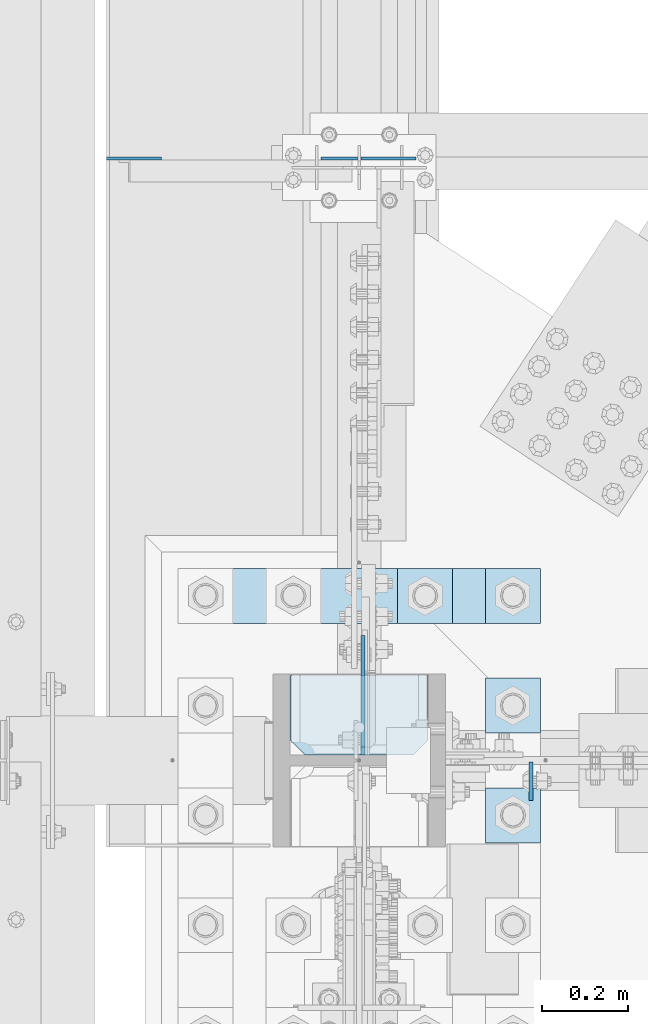
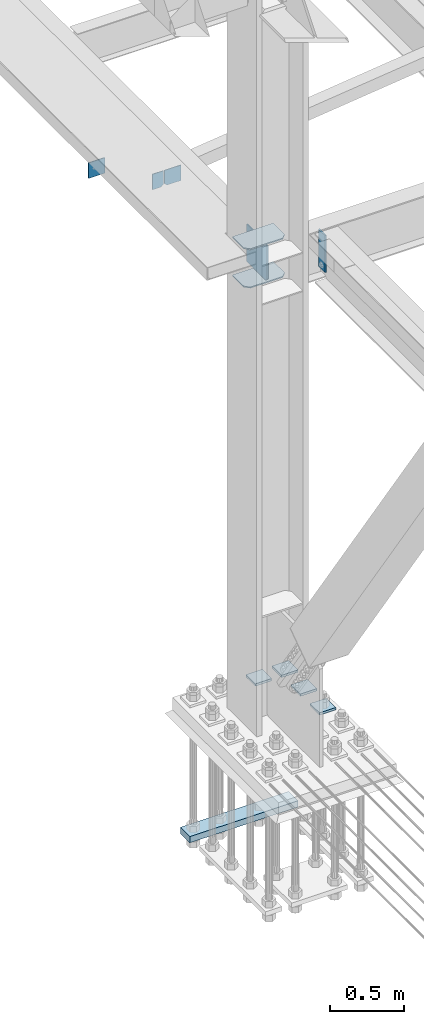
# One storey, part 3275 of 3843: 12 plates, 4 elements without a shape of their own.
"""IFC2X3 building model written with IfcOpenShell, lengths in millimetres."""

import ifcopenshell
import ifcopenshell.guid

model = None  # the IFC model being written
_history = None  # IfcOwnerHistory: only IFC2X3 demands one
_inside = {}  # id of a spatial element -> (the spatial element, [elements in it])
_under = {}  # id of a project, library or spatial element -> (it, [spatial elements below it])
_declared = {}  # id of a project -> (the project, [libraries it declares])
_typed = {}  # id of a type object -> (the type object, [elements of that type])
_made_of = {}  # id of a material, layer set ... -> (it, [elements and type objects made of it])


def new_model(schema):
    """Start an empty IFC model of exactly this schema.

    Asked for "IFC4X3", IfcOpenShell would pick the latest addendum, in which some entities
    have other attributes; the version numbers below select the first issue.
    IFC2X3 requires an IfcOwnerHistory on every rooted entity: one is made here for all.
    """
    global model, _history
    if schema == "IFC4X3":
        model = ifcopenshell.file(schema_version=(4, 3, 0, 0))
    else:
        model = ifcopenshell.file(schema=schema)
    _inside.clear()
    _under.clear()
    _declared.clear()
    _typed.clear()
    _made_of.clear()
    _history = None
    if model.schema == "IFC2X3":
        org = make("IfcOrganization", Name="unknown")
        user = make(
            "IfcPersonAndOrganization",
            ThePerson=make("IfcPerson", FamilyName="unknown"),
            TheOrganization=org,
        )
        app = make(
            "IfcApplication",
            ApplicationDeveloper=org,
            Version="unknown",
            ApplicationFullName="unknown",
            ApplicationIdentifier="unknown",
        )
        _history = make(
            "IfcOwnerHistory",
            OwningUser=user,
            OwningApplication=app,
            ChangeAction="ADDED",
            CreationDate=0,
        )
    return model


def make(cls, **values):
    """One entity of the class cls with the attributes given. An attribute that is None is left unset."""
    return model.create_entity(
        cls, **{name: value for name, value in values.items() if value is not None}
    )


def rooted(cls, **values):
    """An entity with a GlobalId (a new one), such as an element, a storey or a relation."""
    return make(cls, GlobalId=ifcopenshell.guid.new(), OwnerHistory=_history, **values)


def si_unit(unit_type, name, prefix=None):
    """IfcSIUnit, for example si_unit("LENGTHUNIT", "METRE", prefix="MILLI")."""
    return make("IfcSIUnit", UnitType=unit_type, Prefix=prefix, Name=name)


def assignment(units):
    """IfcUnitAssignment: the units of a project."""
    return None if units is None else make("IfcUnitAssignment", Units=units)


def point(xyz):
    """IfcCartesianPoint."""
    return None if xyz is None else make("IfcCartesianPoint", Coordinates=xyz)


def direction(xyz):
    """IfcDirection."""
    return None if xyz is None else make("IfcDirection", DirectionRatios=xyz)


def frame(location, z_axis=None, x_axis=None):
    """IfcAxis2Placement3D, a coordinate frame: its origin and axes. An axis left out is left unset."""
    return make(
        "IfcAxis2Placement3D",
        Location=point(location),
        Axis=direction(z_axis),
        RefDirection=direction(x_axis),
    )


def origin_with_axes():
    """The frame at (0, 0, 0) with the z axis (0, 0, 1) and the x axis (1, 0, 0) written out."""
    return frame((0.0, 0.0, 0.0), z_axis=(0.0, 0.0, 1.0), x_axis=(1.0, 0.0, 0.0))


def place(relative_to, where):
    """IfcLocalPlacement: puts the frame where relative to a parent placement (None: the world)."""
    return make(
        "IfcLocalPlacement", PlacementRelTo=relative_to, RelativePlacement=where
    )


def context(
    kind, dimensions, precision=None, world=None, true_north=None, identifier=None
):
    """IfcGeometricRepresentationContext, for example the 3D "Model" context."""
    return make(
        "IfcGeometricRepresentationContext",
        ContextIdentifier=identifier,
        ContextType=kind,
        CoordinateSpaceDimension=dimensions,
        Precision=precision,
        WorldCoordinateSystem=world,
        TrueNorth=true_north,
    )


def subcontext(parent, identifier, kind, view, scale=None):
    """IfcGeometricRepresentationSubContext, for example "Body" below "Model"."""
    return make(
        "IfcGeometricRepresentationSubContext",
        ContextIdentifier=identifier,
        ContextType=kind,
        ParentContext=parent,
        TargetScale=scale,
        TargetView=view,
    )


def project(units=None, contexts=None):
    """IfcProject with its units and contexts."""
    return rooted(
        "IfcProject",
        Name="project",
        RepresentationContexts=contexts,
        UnitsInContext=assignment(units),
    )


def spatial(cls, under=None, at=None, **own):
    """A site, building, storey or space (cls), placed at a placement, below another one or the project."""
    s = rooted(cls, ObjectPlacement=at, **own)
    if under is not None:
        _under.setdefault(under.id(), (under, []))[1].append(s)
    return s


def faces_of(points, faces, orient=None, outer=None):
    """IfcFace entities. A face is a list of loops; a loop is a list of indices into points, from 0.

    orient and outer hold one flag for each loop. By default every Orientation is true, the
    first loop of a face is its IfcFaceOuterBound and the others are IfcFaceBound.
    """
    made = []
    for i, loops in enumerate(faces):
        bounds = []
        for j, loop in enumerate(loops):
            is_outer = j == 0 if outer is None else outer[i][j]
            bounds.append(
                make(
                    "IfcFaceOuterBound" if is_outer else "IfcFaceBound",
                    Bound=make("IfcPolyLoop", Polygon=[points[k] for k in loop]),
                    Orientation=True if orient is None else orient[i][j],
                )
            )
        made.append(make("IfcFace", Bounds=bounds))
    return made


def faceted_brep(points, faces, orient=None, outer=None, voids=None):
    """IfcFacetedBrep: a solid bounded by flat faces; with voids (closed shells), ...WithVoids."""
    shared = [point(p) for p in points]
    hull = make("IfcClosedShell", CfsFaces=faces_of(shared, faces, orient, outer))
    if voids is None:
        return make("IfcFacetedBrep", Outer=hull)
    return make(
        "IfcFacetedBrepWithVoids",
        Outer=hull,
        Voids=[
            make(cls, CfsFaces=faces_of(shared, fs, o, b)) for cls, fs, o, b in voids
        ],
    )


def shape(context_of_items, identifier, shape_type, items):
    """IfcShapeRepresentation: the items that make up one representation, for example the "Body"."""
    return make(
        "IfcShapeRepresentation",
        ContextOfItems=context_of_items,
        RepresentationIdentifier=identifier,
        RepresentationType=shape_type,
        Items=items,
    )


def material(Name=None, Category=None):
    """IfcMaterial."""
    return make("IfcMaterial", Name=Name, Category=Category)


def made_of(thing, what):
    """Note that an element or type object is made of a material, layer set ...; save() writes the relation."""
    if what is not None:
        _made_of.setdefault(what.id(), (what, []))[1].append(thing)
    return thing


def type_object(cls, material=None, **own):
    """A type object (cls), such as IfcWallType, which elements share."""
    return made_of(rooted(cls, **own), material)


def element(
    cls,
    number,
    at=None,
    inside=None,
    cuts=None,
    type_object=None,
    material=None,
    context=None,
    identifier="Body",
    shape_type=None,
    held_by="IfcProductDefinitionShape",
    body=None,
    shapes=None,
    **own,
):
    """One element of the class cls, such as IfcWall. Its Tag is "e" and its number.

    at: its placement. inside: the storey or other place that contains it. cuts: it is an
    opening in that element (IfcRelVoidsElement). A single representation is given by context,
    identifier, shape_type and body (its items); several are given by shapes. held_by: the class
    of the entity that holds the representations. save() writes the other relations.
    """
    e = rooted(cls, Tag="e%d" % number, ObjectPlacement=at, **own)
    if body is not None:
        shapes = [shape(context, identifier, shape_type, body)]
    if shapes is not None:
        e.Representation = make(held_by, Representations=shapes)
    if inside is not None:
        _inside.setdefault(inside.id(), (inside, []))[1].append(e)
    if cuts is not None:
        rooted(
            "IfcRelVoidsElement", RelatingBuildingElement=cuts, RelatedOpeningElement=e
        )
    if type_object is not None:
        _typed.setdefault(type_object.id(), (type_object, []))[1].append(e)
    return made_of(e, material)


def aggregate(whole, parts):
    """IfcRelAggregates: a whole, such as a stair, and the parts it consists of."""
    return rooted("IfcRelAggregates", RelatingObject=whole, RelatedObjects=parts)


def save(model, path):
    """Write the relations noted so far, then the file.

    IfcRelAggregates (storeys below a building ...), IfcRelContainedInSpatialStructure (elements
    in a storey), IfcRelDefinesByType, IfcRelAssociatesMaterial and IfcRelDeclares: one each for
    every whole, place, type object, material and project.
    """
    for whole, parts in _under.values():
        aggregate(whole, parts)
    for where, things in _inside.values():
        rooted(
            "IfcRelContainedInSpatialStructure",
            RelatedElements=things,
            RelatingStructure=where,
        )
    for kind, things in _typed.values():
        rooted("IfcRelDefinesByType", RelatedObjects=things, RelatingType=kind)
    for what, things in _made_of.values():
        rooted("IfcRelAssociatesMaterial", RelatedObjects=things, RelatingMaterial=what)
    for by, libraries in _declared.values():
        rooted("IfcRelDeclares", RelatingContext=by, RelatedDefinitions=libraries)
    model.write(path)


model = new_model("IFC2X3")

# Units and contexts
model_context = context("Model", 3, precision=1e-05, world=origin_with_axes())
body_context = subcontext(model_context, "Body", "Model", "MODEL_VIEW")
ifc_project = project(units=[si_unit("LENGTHUNIT", "METRE", prefix="MILLI"), si_unit("AREAUNIT", "SQUARE_METRE"), si_unit("VOLUMEUNIT", "CUBIC_METRE"), si_unit("MASSUNIT", "GRAM", prefix="KILO"), si_unit("TIMEUNIT", "SECOND"), si_unit("PLANEANGLEUNIT", "RADIAN"), si_unit("SOLIDANGLEUNIT", "STERADIAN"), si_unit("THERMODYNAMICTEMPERATUREUNIT", "DEGREE_CELSIUS"), si_unit("LUMINOUSINTENSITYUNIT", "LUMEN")], contexts=[model_context])

# Site, building, storey
site_placement = place(None, origin_with_axes())
site = spatial("IfcSite", under=ifc_project, at=site_placement, CompositionType="ELEMENT")
building_placement = place(site_placement, origin_with_axes())
building = spatial("IfcBuilding", under=site, at=building_placement, Name="Undefined", CompositionType="ELEMENT")
storey_placement = place(building_placement, origin_with_axes())
storey = spatial("IfcBuildingStorey", under=building, at=storey_placement, Name="Undefined", CompositionType="ELEMENT", Elevation=0.0)

# Assembly, plate
assembly_1_placement = place(storey_placement, origin_with_axes())
assembly_1 = element("IfcElementAssembly", 1, at=assembly_1_placement, inside=storey, Name="BEAM", AssemblyPlace="NOTDEFINED", PredefinedType="RIGID_FRAME")
ifc_material = material(Name="STEEL/A572-50")
plate_type_1 = type_object("IfcPlateType", PredefinedType="NOTDEFINED")
plate_1_placement = place(assembly_1_placement, frame((36973.66875, 58912.125, 33997.9), z_axis=(0.0, -1.0, 0.0), x_axis=(0.0, 0.0, -1.0)))
plate_1 = element("IfcPlate", 2, at=plate_1_placement, type_object=plate_type_1, material=ifc_material, Name="PLATE", context=body_context, shape_type="Brep", body=[
    faceted_brep([(0.0, -4.76249999999709, 0.0), (0.0, -4.76249999999709, 88.9000015258789), (0.0, 4.76249999999709, 88.9000015258789), (0.0, 4.76249999999709, 0.0), (304.800000000003, -4.76249999999709, 88.8999999999942), (304.800000000003, 4.76249999999709, 88.8999999999942), (304.800000000003, -4.76249999999709, 0.0), (304.800000000003, 4.76249999999709, 0.0)], [[[0, 1, 2, 3]], [[1, 4, 5, 2]], [[4, 6, 7, 5]], [[6, 0, 3, 7]], [[5, 7, 3, 2]], [[6, 4, 1, 0]]]),
])
aggregate(assembly_1, [plate_1])

# Assembly, plates
assembly_2_placement = place(storey_placement, origin_with_axes())
assembly_2 = element("IfcElementAssembly", 3, at=assembly_2_placement, inside=storey, Name="BEAM", AssemblyPlace="NOTDEFINED", PredefinedType="RIGID_FRAME")
plate_type_2 = type_object("IfcPlateType", PredefinedType="NOTDEFINED")
plate_2_placement = place(assembly_2_placement, frame((36579.96875, 60308.033594, 33769.3), z_axis=(0.0, 0.0, -1.0), x_axis=(1.0, 0.0, 0.0)))
plate_2 = element("IfcPlate", 4, at=plate_2_placement, type_object=plate_type_2, material=ifc_material, Name="PLATE", context=body_context, shape_type="Brep", body=[
    faceted_brep([(0.0, -3.17499999999927, 0.0), (0.0, -3.17500000000291, 107.950000000004), (0.0, 3.17500000000291, 107.950000000004), (0.0, 3.17499999999927, 0.0), (19.0500000000029, -3.17500000000291, 127.0), (19.0500000000029, 3.17500000000291, 127.0), (127.0, -3.17500000000291, 127.0), (127.0, 3.17500000000291, 127.0), (127.0, -3.17500000000291, 0.0), (127.0, 3.17500000000291, 0.0)], [[[0, 1, 2, 3]], [[1, 4, 5, 2]], [[4, 6, 7, 5]], [[6, 8, 9, 7]], [[8, 0, 3, 9]], [[5, 7, 9, 3, 2]], [[8, 6, 4, 1, 0]]]),
])
plate_3_placement = place(assembly_2_placement, frame((35991.8000305176, 60308.0335940001, 33909.0000061035), z_axis=(0.0, 0.0, 1.0), x_axis=(1.0, 0.0, 0.0)))
plate_3 = element("IfcPlate", 5, at=plate_3_placement, type_object=plate_type_2, material=ifc_material, Name="PLATE", context=body_context, shape_type="Brep", body=[
    faceted_brep([(0.0, -3.17499999999927, 0.0), (-6.10351708019152e-06, -3.17500000000291, 126.999993896483), (-6.10351708019152e-06, 3.17500000000291, 126.999993896483), (0.0, 3.17499999999927, 0.0), (127.0, -3.17500000000291, 127.0), (127.0, 3.17500000000291, 127.0), (127.0, -3.17500000000291, 0.0), (127.0, 3.17500000000291, 0.0)], [[[0, 1, 2, 3]], [[1, 4, 5, 2]], [[4, 6, 7, 5]], [[6, 0, 3, 7]], [[5, 7, 3, 2]], [[6, 4, 1, 0]]]),
])
plate_type_3 = type_object("IfcPlateType", PredefinedType="NOTDEFINED")
plate_4_placement = place(assembly_2_placement, frame((36572.0312591215, 60308.033594, 33769.3), z_axis=(0.0, 0.0, -1.0), x_axis=(-1.0, 0.0, 0.0)))
plate_4 = element("IfcPlate", 6, at=plate_4_placement, type_object=plate_type_3, material=ifc_material, Name="PLATE", context=body_context, shape_type="Brep", body=[
    faceted_brep([(0.0, -3.17499999999927, 0.0), (0.0, -3.17500000000291, 107.950000000004), (0.0, 3.17500000000291, 107.950000000004), (0.0, 3.17499999999927, 0.0), (19.0500000000029, -3.17500000000291, 127.0), (19.0500000000029, 3.17500000000291, 127.0), (84.9312591264534, -3.17500000000291, 126.999993896701), (84.9312591264534, 3.17500000000291, 126.999993896701), (84.9312500000015, -3.17500000000291, 2.18278728425503e-10), (84.9312500000015, 3.17500000000291, 2.18278728425503e-10)], [[[0, 1, 2, 3]], [[1, 4, 5, 2]], [[4, 6, 7, 5]], [[6, 8, 9, 7]], [[8, 0, 3, 9]], [[5, 7, 9, 3, 2]], [[8, 6, 4, 1, 0]]]),
])
aggregate(assembly_2, [plate_2, plate_4, plate_3])

assembly_3_placement = place(storey_placement, origin_with_axes())
assembly_3 = element("IfcElementAssembly", 7, at=assembly_3_placement, inside=storey, Name="COLUMN", AssemblyPlace="NOTDEFINED", PredefinedType="RIGID_FRAME")
plate_type_4 = type_object("IfcPlateType", PredefinedType="NOTDEFINED")
plate_5_placement = place(assembly_3_placement, frame((36734.75, 59112.15, 33688.3375), z_axis=(-1.0, 0.0, 0.0), x_axis=(0.0, -1.0, 0.0)))
plate_5 = element("IfcPlate", 8, at=plate_5_placement, type_object=plate_type_4, material=ifc_material, Name="PLATE", context=body_context, shape_type="Brep", body=[
    faceted_brep([(0.0, -4.76249999999709, 0.0), (0.0, -4.76249999785796, 317.500000005042), (0.0, 4.76250000210712, 317.50000000505), (0.0, 4.76249999999709, 0.0), (150.81249847413, -4.76249999999709, 317.5), (150.81249847413, 4.76249999999709, 317.5), (184.150000000009, -4.76249999999709, 284.162498474121), (184.150000000009, 4.76249999999709, 284.162498474121), (184.150000000009, -4.76249999999709, 33.3375015258789), (184.150000000009, 4.76249999999709, 33.3375015258789), (150.81249847413, -4.76249999999709, 0.0), (150.81249847413, 4.76249999999709, 0.0)], [[[0, 1, 2, 3]], [[1, 4, 5, 2]], [[4, 6, 7, 5]], [[6, 8, 9, 7]], [[8, 10, 11, 9]], [[10, 0, 3, 11]], [[5, 7, 9, 11, 3, 2]], [[10, 8, 6, 4, 1, 0]]]),
])
plate_6_placement = place(assembly_3_placement, frame((36734.75, 59112.15, 34002.6625), z_axis=(-1.0, 0.0, 0.0), x_axis=(0.0, -1.0, 0.0)))
plate_6 = element("IfcPlate", 9, at=plate_6_placement, type_object=plate_type_4, material=ifc_material, Name="PLATE", context=body_context, shape_type="Brep", body=[
    faceted_brep([(0.0, -4.76249999999709, 0.0), (0.0, -4.76249999785796, 317.500000005042), (0.0, 4.76250000210712, 317.50000000505), (0.0, 4.76249999999709, 0.0), (150.81249847413, -4.76249999999709, 317.5), (150.81249847413, 4.76249999999709, 317.5), (184.150000000009, -4.76249999999709, 284.162498474121), (184.150000000009, 4.76249999999709, 284.162498474121), (184.150000000009, -4.76249999999709, 33.3375015258789), (184.150000000009, 4.76249999999709, 33.3375015258789), (150.81249847413, -4.76249999999709, 0.0), (150.81249847413, 4.76249999999709, 0.0)], [[[0, 1, 2, 3]], [[1, 4, 5, 2]], [[4, 6, 7, 5]], [[6, 8, 9, 7]], [[8, 10, 11, 9]], [[10, 0, 3, 11]], [[5, 7, 9, 11, 3, 2]], [[10, 8, 6, 4, 1, 0]]]),
])
plate_type_5 = type_object("IfcPlateType", PredefinedType="NOTDEFINED")
plate_7_placement = place(assembly_3_placement, frame((36584.73125, 58928.0, 33712.1500027914), z_axis=(0.0, 0.707106781186548, 0.707106781186548), x_axis=(5.70000238222118e-08, 0.707106781186546, -0.707106781186546)))
plate_7 = element("IfcPlate", 10, at=plate_7_placement, type_object=plate_type_5, material=ifc_material, Name="PLATE", context=body_context, shape_type="Brep", body=[
    faceted_brep([(0.0, -4.76249999999709, 0.0), (-188.585379946875, -4.76249999999709, 188.585377136231), (-188.585379946875, 4.76249999999709, 188.585377136231), (0.0, 4.76249999999709, 0.0), (-188.585379946759, -4.76249999999709, 215.526145298725), (-188.585379946759, 4.76249999999709, 215.526145298725), (-6.73518993152538, -4.76249999999709, 397.376334478104), (-6.73518993152538, 4.76249999999709, 397.376334478104), (208.790958579193, -4.76249999999709, 181.850189179575), (208.790958579193, 4.76249999999709, 181.850189179575), (26.9407683631998, -4.76249999999709, 1.30967237055302e-10), (26.9407683631998, 4.76249999999709, 1.30967237055302e-10)], [[[0, 1, 2, 3]], [[1, 4, 5, 2]], [[4, 6, 7, 5]], [[6, 8, 9, 7]], [[8, 10, 11, 9]], [[10, 0, 3, 11]], [[5, 7, 9, 11, 3, 2]], [[10, 8, 6, 4, 1, 0]]]),
])
aggregate(assembly_3, [plate_5, plate_6, plate_7])

assembly_4_placement = place(storey_placement, origin_with_axes())
assembly_4 = element("IfcElementAssembly", 11, at=assembly_4_placement, inside=storey, Name="TEMPLATE", AssemblyPlace="NOTDEFINED", PredefinedType="RIGID_FRAME")
plate_type_6 = type_object("IfcPlateType", PredefinedType="NOTDEFINED")
plate_8_placement = place(assembly_4_placement, frame((36868.1, 58851.8, 30172.025), z_axis=(0.0, -1.0, 0.0), x_axis=(1.0, 0.0, 0.0)))
plate_8 = element("IfcPlate", 12, at=plate_8_placement, type_object=plate_type_6, material=ifc_material, Name="Washer Plate", context=body_context, shape_type="Brep", body=[
    faceted_brep([(0.0, -9.52500000000146, 0.0), (0.0, -9.52499999999418, 127.0), (0.0, 9.52499999999418, 127.0), (0.0, 9.52500000000146, 0.0), (127.0, -9.52500000000146, 127.0), (127.0, 9.52500000000146, 127.0), (127.0, -9.52500000000146, 0.0), (127.0, 9.52500000000146, 0.0)], [[[0, 1, 2, 3]], [[1, 4, 5, 2]], [[4, 6, 7, 5]], [[6, 0, 3, 7]], [[5, 7, 3, 2]], [[6, 4, 1, 0]]]),
])
plate_9_placement = place(assembly_4_placement, frame((36868.1, 59105.8, 30172.025), z_axis=(0.0, -1.0, 0.0), x_axis=(1.0, 0.0, 0.0)))
plate_9 = element("IfcPlate", 13, at=plate_9_placement, type_object=plate_type_6, material=ifc_material, Name="Washer Plate", context=body_context, shape_type="Brep", body=[
    faceted_brep([(0.0, -9.52500000000146, 0.0), (0.0, -9.52499999999418, 127.0), (0.0, 9.52499999999418, 127.0), (0.0, 9.52500000000146, 0.0), (127.0, -9.52500000000146, 127.0), (127.0, 9.52500000000146, 127.0), (127.0, -9.52500000000146, 0.0), (127.0, 9.52500000000146, 0.0)], [[[0, 1, 2, 3]], [[1, 4, 5, 2]], [[4, 6, 7, 5]], [[6, 0, 3, 7]], [[5, 7, 3, 2]], [[6, 4, 1, 0]]]),
])
plate_10_placement = place(assembly_4_placement, frame((36868.1, 59359.8, 30172.025), z_axis=(0.0, -1.0, 0.0), x_axis=(1.0, 0.0, 0.0)))
plate_10 = element("IfcPlate", 14, at=plate_10_placement, type_object=plate_type_6, material=ifc_material, Name="Washer Plate", context=body_context, shape_type="Brep", body=[
    faceted_brep([(0.0, -9.52500000000146, 0.0), (0.0, -9.52499999999418, 127.0), (0.0, 9.52499999999418, 127.0), (0.0, 9.52500000000146, 0.0), (127.0, -9.52500000000146, 127.0), (127.0, 9.52500000000146, 127.0), (127.0, -9.52500000000146, 0.0), (127.0, 9.52500000000146, 0.0)], [[[0, 1, 2, 3]], [[1, 4, 5, 2]], [[4, 6, 7, 5]], [[6, 0, 3, 7]], [[5, 7, 3, 2]], [[6, 4, 1, 0]]]),
])
plate_11_placement = place(assembly_4_placement, frame((36664.9, 59359.8, 30172.025), z_axis=(0.0, -1.0, 0.0), x_axis=(1.0, 0.0, 0.0)))
plate_11 = element("IfcPlate", 15, at=plate_11_placement, type_object=plate_type_6, material=ifc_material, Name="Washer Plate", context=body_context, shape_type="Brep", body=[
    faceted_brep([(0.0, -9.52500000000146, 0.0), (0.0, -9.52499999999418, 127.0), (0.0, 9.52499999999418, 127.0), (0.0, 9.52500000000146, 0.0), (127.0, -9.52500000000146, 127.0), (127.0, 9.52500000000146, 127.0), (127.0, -9.52500000000146, 0.0), (127.0, 9.52500000000146, 0.0)], [[[0, 1, 2, 3]], [[1, 4, 5, 2]], [[4, 6, 7, 5]], [[6, 0, 3, 7]], [[5, 7, 3, 2]], [[6, 4, 1, 0]]]),
])
plate_type_7 = type_object("IfcPlateType", PredefinedType="NOTDEFINED")
plate_12_placement = place(assembly_4_placement, frame((36995.1, 59359.8, 29083.0), z_axis=(-1.0, 0.0, 0.0), x_axis=(0.0, -1.0, 0.0)))
plate_12 = element("IfcPlate", 16, at=plate_12_placement, type_object=plate_type_7, material=ifc_material, Name="PLATE", context=body_context, shape_type="Brep", body=[
    faceted_brep([(0.0, -25.3999996185303, 0.0), (0.0, -25.4000000000015, 838.200012207031), (0.0, 25.4000000000015, 838.200012207031), (0.0, 25.3999996185303, 0.0), (127.0, -25.4000000000015, 838.200012207031), (127.0, 25.4000000000015, 838.200012207031), (127.0, -25.4000000000015, 0.0), (127.0, 25.4000000000015, 0.0)], [[[0, 1, 2, 3]], [[1, 4, 5, 2]], [[4, 6, 7, 5]], [[6, 0, 3, 7]], [[5, 7, 3, 2]], [[6, 4, 1, 0]]]),
])
aggregate(assembly_4, [plate_8, plate_9, plate_10, plate_11, plate_12])

save(model, "model.ifc")
